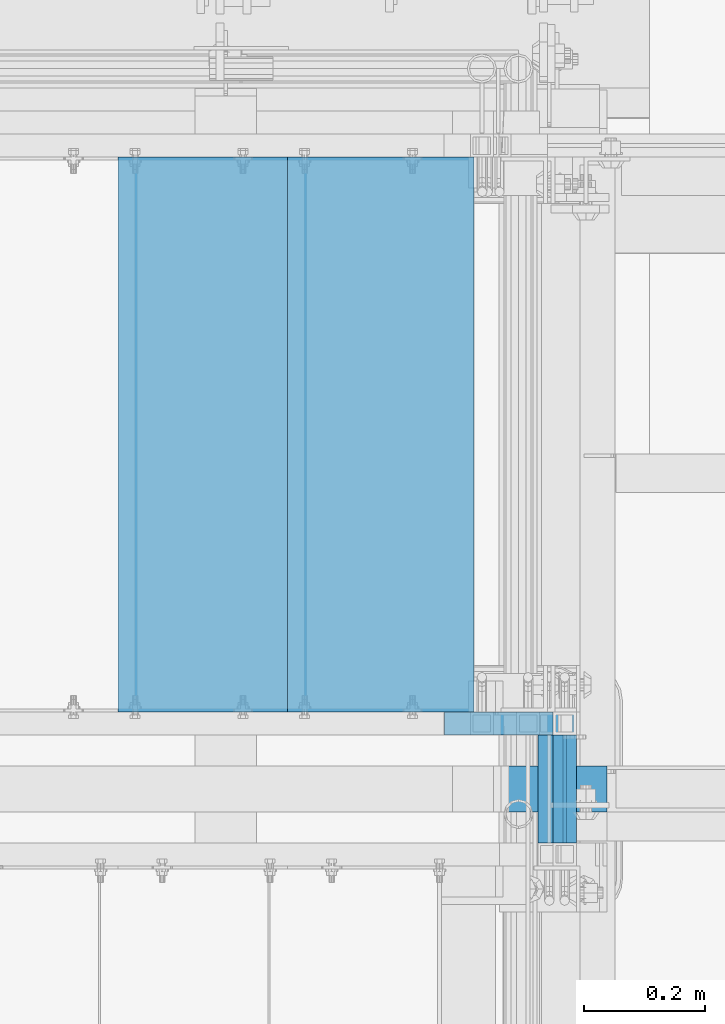
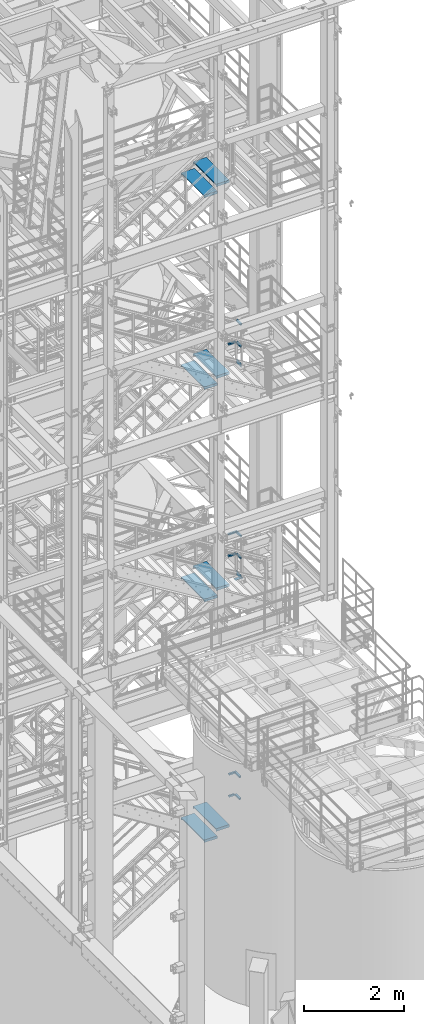
# One storey, part 1198 of 1876: 22 beams, 8 elements without a shape of their own.
"""IFC2X3 building model written with IfcOpenShell, lengths in millimetres."""

from ifc_helpers import new_model, si_unit, frame, origin_with_axes, place, context, subcontext, project, spatial, faceted_brep, material, type_object, element, aggregate, save


model = new_model("IFC2X3")

# Units and contexts
model_context = context("Model", 3, precision=1e-05, world=origin_with_axes())
body_context = subcontext(model_context, "Body", "Model", "MODEL_VIEW")
ifc_project = project(units=[si_unit("LENGTHUNIT", "METRE", prefix="MILLI"), si_unit("AREAUNIT", "SQUARE_METRE"), si_unit("VOLUMEUNIT", "CUBIC_METRE"), si_unit("MASSUNIT", "GRAM", prefix="KILO"), si_unit("TIMEUNIT", "SECOND"), si_unit("PLANEANGLEUNIT", "RADIAN"), si_unit("SOLIDANGLEUNIT", "STERADIAN"), si_unit("THERMODYNAMICTEMPERATUREUNIT", "DEGREE_CELSIUS"), si_unit("LUMINOUSINTENSITYUNIT", "LUMEN")], contexts=[model_context])

# Site, building, storey
site_placement = place(None, origin_with_axes())
site = spatial("IfcSite", under=ifc_project, at=site_placement, CompositionType="ELEMENT")
building_placement = place(site_placement, origin_with_axes())
building = spatial("IfcBuilding", under=site, at=building_placement, Name="Undefined", CompositionType="ELEMENT")
storey_placement = place(building_placement, origin_with_axes())
storey = spatial("IfcBuildingStorey", under=building, at=storey_placement, Name="Undefined", CompositionType="ELEMENT", Elevation=0.0)

# Assembly, beam
assembly_1_placement = place(storey_placement, origin_with_axes())
assembly_1 = element("IfcElementAssembly", 1, at=assembly_1_placement, inside=storey, Name="RAIL", AssemblyPlace="NOTDEFINED", PredefinedType="RIGID_FRAME")
ifc_material_1 = material(Name="STEEL/A36")
beam_type_1 = type_object("IfcBeamType", PredefinedType="NOTDEFINED")
beam_1_placement = place(assembly_1_placement, frame((6273.79999930564, -5753.10000038055, 13382.6249973441), z_axis=(0.0, 0.0, 1.0), x_axis=(0.0, -1.0, 0.0)))
beam_1 = element("IfcBeam", 2, at=beam_1_placement, type_object=beam_type_1, material=ifc_material_1, Name="PLATE", context=body_context, shape_type="Brep", body=[
    faceted_brep([(0.0, 3.17500000000018, -50.8000000000002), (0.0, 3.17500000000018, 50.8000000000002), (177.799998770143, 3.1750000000111, 50.8000000000866), (177.799998770101, 3.1750000000111, -50.7999999999138), (0.0, -3.17500000000018, 50.8000000000002), (177.799998770144, -3.17499999998881, 50.8000000000866), (0.0, -3.17500000000018, -50.8000000000002), (177.799998770101, -3.17499999998881, -50.7999999999138)], [[[0, 1, 2, 3]], [[1, 4, 5, 2]], [[4, 6, 7, 5]], [[6, 0, 3, 7]], [[5, 7, 3, 2]], [[6, 4, 1, 0]]]),
])

assembly_2_placement = place(storey_placement, origin_with_axes())
assembly_2 = element("IfcElementAssembly", 3, at=assembly_2_placement, inside=storey, Name="RAIL", AssemblyPlace="NOTDEFINED", PredefinedType="RIGID_FRAME")
beam_2_placement = place(assembly_2_placement, frame((6273.79999336881, -5753.10000038054, 8226.42499734427), z_axis=(0.0, 0.0, 1.0), x_axis=(0.0, -1.0, 0.0)))
beam_2 = element("IfcBeam", 4, at=beam_2_placement, type_object=beam_type_1, material=ifc_material_1, Name="PLATE", context=body_context, shape_type="Brep", body=[
    faceted_brep([(0.0, 3.17500000000018, -50.8000000000002), (0.0, 3.17500000000018, 50.8000000000002), (177.799998770143, 3.1750000000111, 50.8000000000866), (177.799998770101, 3.1750000000111, -50.7999999999138), (0.0, -3.17500000000018, 50.8000000000002), (177.799998770144, -3.17499999998881, 50.8000000000866), (0.0, -3.17500000000018, -50.8000000000002), (177.799998770101, -3.17499999998881, -50.7999999999138)], [[[0, 1, 2, 3]], [[1, 4, 5, 2]], [[4, 6, 7, 5]], [[6, 0, 3, 7]], [[5, 7, 3, 2]], [[6, 4, 1, 0]]]),
])

# Beam
ifc_material_2 = material()
beam_type_2 = type_object("IfcBeamType", Name="HSS1-1/2X1-1/2X1/8", PredefinedType="NOTDEFINED")
beam_3_placement = place(assembly_1_placement, frame((6273.80000001182, -5753.1000003826, 13843.0000000019), z_axis=(0.0, 0.0, -1.0), x_axis=(0.0, -1.0, 0.0)))
beam_3 = element("IfcBeam", 5, at=beam_3_placement, type_object=beam_type_2, material=ifc_material_2, Name="RAIL", ObjectType="HSS1-1/2X1-1/2X1/8", context=body_context, shape_type="Brep", body=[
    faceted_brep([(-7.27595761418343e-12, 15.8749992829999, -15.8749992829999), (-7.27595761418343e-12, -15.8749992829999, -15.8749992829999), (177.800002232287, -15.8749992829999, -15.8749992829999), (177.800002232287, 15.8749992829999, -15.8749992829999), (5.45696821063757e-12, -15.8749992829999, 15.8749992829999), (177.800002232287, -15.8749992829999, 15.8749992829999), (5.45696821063757e-12, 15.8749992829999, 15.8749992829999), (177.800002232287, 15.8749992829999, 15.8749992829999), (0.0, 19.0499992349996, -19.0499992350001), (0.0, 19.0499992349996, 19.0499992349996), (177.800002232287, 19.0499992349996, 19.0499992349996), (177.800002232287, 19.0499992349996, -19.0499992349996), (0.0, -19.0499992349996, 19.0499992349996), (177.800002232287, -19.0499992349996, 19.0499992349996), (0.0, -19.0499992349996, -19.0499992350001), (177.800002232287, -19.0499992349996, -19.0499992349996)], [[[0, 1, 2, 3]], [[1, 4, 5, 2]], [[4, 6, 7, 5]], [[6, 0, 3, 7]], [[8, 9, 10, 11]], [[9, 12, 13, 10]], [[12, 14, 15, 13]], [[14, 8, 11, 15]], [[13, 15, 11, 10], [5, 7, 3, 2]], [[14, 12, 9, 8], [6, 4, 1, 0]]]),
])

beam_4_placement = place(assembly_1_placement, frame((6273.80000001181, -5753.10000038054, 14376.4000000043), z_axis=(0.0, 0.0, -1.0), x_axis=(0.0, -1.0, 0.0)))
beam_4 = element("IfcBeam", 6, at=beam_4_placement, type_object=beam_type_2, material=ifc_material_2, Name="RAIL", ObjectType="HSS1-1/2X1-1/2X1/8", context=body_context, shape_type="Brep", body=[
    faceted_brep([(-7.27595761418343e-12, 15.8749992829999, -15.8749992829999), (-7.27595761418343e-12, -15.8749992829999, -15.8749992829999), (177.800002232287, -15.8749992829999, -15.8749992829999), (177.800002232287, 15.8749992829999, -15.8749992829999), (5.45696821063757e-12, -15.8749992829999, 15.8749992829999), (177.800002232287, -15.8749992829999, 15.8749992829999), (5.45696821063757e-12, 15.8749992829999, 15.8749992829999), (177.800002232287, 15.8749992829999, 15.8749992829999), (0.0, 19.0499992349996, -19.0499992350001), (0.0, 19.0499992349996, 19.0499992349996), (177.800002232287, 19.0499992349996, 19.0499992349996), (177.800002232287, 19.0499992349996, -19.0499992349996), (0.0, -19.0499992349996, 19.0499992349996), (177.800002232287, -19.0499992349996, 19.0499992349996), (0.0, -19.0499992349996, -19.0499992350001), (177.800002232287, -19.0499992349996, -19.0499992349996)], [[[0, 1, 2, 3]], [[1, 4, 5, 2]], [[4, 6, 7, 5]], [[6, 0, 3, 7]], [[8, 9, 10, 11]], [[9, 12, 13, 10]], [[12, 14, 15, 13]], [[14, 8, 11, 15]], [[13, 15, 11, 10], [5, 7, 3, 2]], [[14, 12, 9, 8], [6, 4, 1, 0]]]),
])

beam_5_placement = place(assembly_2_placement, frame((6273.79999407513, -5753.1000003826, 8686.80000000203), z_axis=(0.0, 0.0, -1.0), x_axis=(0.0, -1.0, 0.0)))
beam_5 = element("IfcBeam", 7, at=beam_5_placement, type_object=beam_type_2, material=ifc_material_2, Name="RAIL", ObjectType="HSS1-1/2X1-1/2X1/8", context=body_context, shape_type="Brep", body=[
    faceted_brep([(-7.27595761418343e-12, 15.8749992829999, -15.8749992829999), (-7.27595761418343e-12, -15.8749992829999, -15.8749992829999), (177.800002232287, -15.8749992829999, -15.8749992829999), (177.800002232287, 15.8749992829999, -15.8749992829999), (5.45696821063757e-12, -15.8749992829999, 15.8749992829999), (177.800002232287, -15.8749992829999, 15.8749992829999), (5.45696821063757e-12, 15.8749992829999, 15.8749992829999), (177.800002232287, 15.8749992829999, 15.8749992829999), (0.0, 19.0499992349996, -19.0499992350001), (0.0, 19.0499992349996, 19.0499992349996), (177.800002232287, 19.0499992349996, 19.0499992349996), (177.800002232287, 19.0499992349996, -19.0499992349996), (0.0, -19.0499992349996, 19.0499992349996), (177.800002232287, -19.0499992349996, 19.0499992349996), (0.0, -19.0499992349996, -19.0499992350001), (177.800002232287, -19.0499992349996, -19.0499992349996)], [[[0, 1, 2, 3]], [[1, 4, 5, 2]], [[4, 6, 7, 5]], [[6, 0, 3, 7]], [[8, 9, 10, 11]], [[9, 12, 13, 10]], [[12, 14, 15, 13]], [[14, 8, 11, 15]], [[13, 15, 11, 10], [5, 7, 3, 2]], [[14, 12, 9, 8], [6, 4, 1, 0]]]),
])

beam_6_placement = place(assembly_2_placement, frame((6273.79999407512, -5753.10000038054, 9220.20000000107), z_axis=(0.0, 0.0, -1.0), x_axis=(0.0, -1.0, 0.0)))
beam_6 = element("IfcBeam", 8, at=beam_6_placement, type_object=beam_type_2, material=ifc_material_2, Name="RAIL", ObjectType="HSS1-1/2X1-1/2X1/8", context=body_context, shape_type="Brep", body=[
    faceted_brep([(-7.27595761418343e-12, 15.8749992829999, -15.8749992829999), (-7.27595761418343e-12, -15.8749992829999, -15.8749992829999), (177.800002232287, -15.8749992829999, -15.8749992829999), (177.800002232287, 15.8749992829999, -15.8749992829999), (5.45696821063757e-12, -15.8749992829999, 15.8749992829999), (177.800002232287, -15.8749992829999, 15.8749992829999), (5.45696821063757e-12, 15.8749992829999, 15.8749992829999), (177.800002232287, 15.8749992829999, 15.8749992829999), (0.0, 19.0499992349996, -19.0499992350001), (0.0, 19.0499992349996, 19.0499992349996), (177.800002232287, 19.0499992349996, 19.0499992349996), (177.800002232287, 19.0499992349996, -19.0499992349996), (0.0, -19.0499992349996, 19.0499992349996), (177.800002232287, -19.0499992349996, 19.0499992349996), (0.0, -19.0499992349996, -19.0499992350001), (177.800002232287, -19.0499992349996, -19.0499992349996)], [[[0, 1, 2, 3]], [[1, 4, 5, 2]], [[4, 6, 7, 5]], [[6, 0, 3, 7]], [[8, 9, 10, 11]], [[9, 12, 13, 10]], [[12, 14, 15, 13]], [[14, 8, 11, 15]], [[13, 15, 11, 10], [5, 7, 3, 2]], [[14, 12, 9, 8], [6, 4, 1, 0]]]),
])

# Assembly, beams
assembly_3_placement = place(storey_placement, origin_with_axes())
assembly_3 = element("IfcElementAssembly", 9, at=assembly_3_placement, inside=storey, Name="RAIL", AssemblyPlace="NOTDEFINED", PredefinedType="RIGID_FRAME")
beam_7_placement = place(assembly_3_placement, frame((6248.400000012, -5753.1000003826, 2837.68341294587), z_axis=(0.0, 0.0, -1.0), x_axis=(0.0, -1.0, 0.0)))
beam_7 = element("IfcBeam", 10, at=beam_7_placement, type_object=beam_type_2, material=ifc_material_2, Name="RAIL", ObjectType="HSS1-1/2X1-1/2X1/8", context=body_context, shape_type="Brep", body=[
    faceted_brep([(-7.27595761418343e-12, 15.8749992829999, -15.8749992829999), (-7.27595761418343e-12, -15.8749992829999, -15.8749992829999), (177.800002232287, -15.8749992829999, -15.8749992829999), (177.800002232287, 15.8749992829999, -15.8749992829999), (5.45696821063757e-12, -15.8749992829999, 15.8749992829999), (177.800002232287, -15.8749992829999, 15.8749992829999), (5.45696821063757e-12, 15.8749992829999, 15.8749992829999), (177.800002232287, 15.8749992829999, 15.8749992829999), (0.0, 19.0499992349996, -19.0499992350001), (0.0, 19.0499992349996, 19.0499992349996), (177.800002232287, 19.0499992349996, 19.0499992349996), (177.800002232287, 19.0499992349996, -19.0499992349996), (0.0, -19.0499992349996, 19.0499992349996), (177.800002232287, -19.0499992349996, 19.0499992349996), (0.0, -19.0499992349996, -19.0499992350001), (177.800002232287, -19.0499992349996, -19.0499992349996)], [[[0, 1, 2, 3]], [[1, 4, 5, 2]], [[4, 6, 7, 5]], [[6, 0, 3, 7]], [[8, 9, 10, 11]], [[9, 12, 13, 10]], [[12, 14, 15, 13]], [[14, 8, 11, 15]], [[13, 15, 11, 10], [5, 7, 3, 2]], [[14, 12, 9, 8], [6, 4, 1, 0]]]),
])
beam_8_placement = place(assembly_3_placement, frame((6248.40000001199, -5753.10000038054, 3371.08362061188), z_axis=(0.0, 0.0, -1.0), x_axis=(0.0, -1.0, 0.0)))
beam_8 = element("IfcBeam", 11, at=beam_8_placement, type_object=beam_type_2, material=ifc_material_2, Name="RAIL", ObjectType="HSS1-1/2X1-1/2X1/8", context=body_context, shape_type="Brep", body=[
    faceted_brep([(-7.27595761418343e-12, 15.8749992829999, -15.8749992829999), (-7.27595761418343e-12, -15.8749992829999, -15.8749992829999), (177.800002232287, -15.8749992829999, -15.8749992829999), (177.800002232287, 15.8749992829999, -15.8749992829999), (5.45696821063757e-12, -15.8749992829999, 15.8749992829999), (177.800002232287, -15.8749992829999, 15.8749992829999), (5.45696821063757e-12, 15.8749992829999, 15.8749992829999), (177.800002232287, 15.8749992829999, 15.8749992829999), (0.0, 19.0499992349996, -19.0499992350001), (0.0, 19.0499992349996, 19.0499992349996), (177.800002232287, 19.0499992349996, 19.0499992349996), (177.800002232287, 19.0499992349996, -19.0499992349996), (0.0, -19.0499992349996, 19.0499992349996), (177.800002232287, -19.0499992349996, 19.0499992349996), (0.0, -19.0499992349996, -19.0499992350001), (177.800002232287, -19.0499992349996, -19.0499992349996)], [[[0, 1, 2, 3]], [[1, 4, 5, 2]], [[4, 6, 7, 5]], [[6, 0, 3, 7]], [[8, 9, 10, 11]], [[9, 12, 13, 10]], [[12, 14, 15, 13]], [[14, 8, 11, 15]], [[13, 15, 11, 10], [5, 7, 3, 2]], [[14, 12, 9, 8], [6, 4, 1, 0]]]),
])
beam_9_placement = place(assembly_3_placement, frame((6096.00000038111, -5734.05000114554, 2837.68362061127), z_axis=(0.0, 0.0, 1.0), x_axis=(1.0, 0.0, 0.0)))
beam_9 = element("IfcBeam", 12, at=beam_9_placement, type_object=beam_type_2, material=ifc_material_2, Name="RAIL", ObjectType="HSS1-1/2X1-1/2X1/8", context=body_context, shape_type="Brep", body=[
    faceted_brep([(4.61079483309095, 15.8749992829999, -15.8749992829999), (4.61079483309095, -15.8749992829999, -15.8749992829999), (133.350000395892, -15.8749992829999, -15.8749992829999), (133.350000395892, 15.8749992829999, -15.8749992829999), (-4.61079482670993, -15.8749992829999, 15.8749992829999), (133.350000395892, -15.8749992829999, 15.8749992829999), (-4.61079482670993, 15.8749992829999, 15.8749992829999), (133.350000395892, 15.8749992829999, 15.8749992829999), (5.5329538267797, 19.0499992349996, -19.0499992350001), (-5.53295382039778, 19.0499992349996, 19.0499992350001), (133.350000395892, 19.0499992349996, 19.0499992350001), (133.350000395892, 19.0499992349996, -19.0499992350001), (-5.53295382039778, -19.0499992349996, 19.0499992350001), (133.350000395892, -19.0499992349996, 19.0499992350001), (5.5329538267797, -19.0499992349996, -19.0499992350001), (133.350000395892, -19.0499992349996, -19.0499992350001)], [[[0, 1, 2, 3]], [[1, 4, 5, 2]], [[4, 6, 7, 5]], [[6, 0, 3, 7]], [[8, 9, 10, 11]], [[9, 12, 13, 10]], [[12, 14, 15, 13]], [[14, 8, 11, 15]], [[13, 15, 11, 10], [5, 7, 3, 2]], [[14, 12, 9, 8], [6, 4, 1, 0]]]),
])
beam_10_placement = place(assembly_3_placement, frame((6248.400000012, -5734.05000114554, 3371.08362061127), z_axis=(0.0, 0.0, -1.0), x_axis=(-1.0, 0.0, 0.0)))
beam_10 = element("IfcBeam", 13, at=beam_10_placement, type_object=beam_type_2, material=ifc_material_2, Name="RAIL", ObjectType="HSS1-1/2X1-1/2X1/8", context=body_context, shape_type="Brep", body=[
    faceted_brep([(-15.875, 15.8749981318675, -15.875), (-15.875, -15.8750000000011, -15.875), (157.010794458642, -15.8749992829999, -15.8749992829999), (157.010794458642, 15.8749992829999, -15.8749992829999), (15.875, -15.8750000000011, 15.875), (147.789204798841, -15.8749992829999, 15.8749992829999), (15.875, 15.8749981318675, 15.875), (147.789204798841, 15.8749992829999, 15.8749992829999), (-19.049999234363, 19.0499992349996, -19.0499992350001), (19.0500000000002, 19.0499992349996, 19.0499992350001), (146.867045805153, 19.0499992349996, 19.0499992350001), (157.93295345233, 19.0499992349996, -19.0499992350001), (19.0500000000002, -19.0499992349996, 19.0499992350001), (146.867045805153, -19.0499992349996, 19.0499992350001), (-19.049999234363, -19.0499992349996, -19.0499992350001), (157.93295345233, -19.0499992349996, -19.0499992350001)], [[[0, 1, 2, 3]], [[1, 4, 5, 2]], [[4, 6, 7, 5]], [[6, 0, 3, 7]], [[8, 9, 10, 11]], [[9, 12, 13, 10]], [[12, 14, 15, 13]], [[14, 8, 11, 15]], [[13, 15, 11, 10], [5, 7, 3, 2]], [[14, 12, 9, 8], [6, 4, 1, 0]]]),
])
aggregate(assembly_3, [beam_7, beam_8, beam_9, beam_10])

# Beam
beam_11_placement = place(assembly_2_placement, frame((6081.03214535802, -5734.05000114554, 8686.8), z_axis=(0.0, 0.0, 1.0), x_axis=(1.0, 0.0, 0.0)))
beam_11 = element("IfcBeam", 14, at=beam_11_placement, type_object=beam_type_2, material=ifc_material_2, Name="RAIL", ObjectType="HSS1-1/2X1-1/2X1/8", context=body_context, shape_type="Brep", body=[
    faceted_brep([(4.62281070603149, 15.8749992829999, -15.8749992829999), (4.62281070603149, -15.8749992829999, -15.8749992829999), (173.717849483728, -15.8749992829999, -15.8749992829999), (173.717849483728, 15.8749992829999, -15.8749992829999), (-4.62281069892288, -15.8749992829999, 15.8749992829999), (173.717849483728, -15.8749992829999, 15.8749992829999), (-4.62281069892288, 15.8749992829999, 15.8749992829999), (173.717849483728, 15.8749992829999, 15.8749992829999), (5.54737287430726, 19.0499992349996, -19.0499992349996), (-5.54737286719865, 19.0499992349996, 19.0499992349996), (173.717849483728, 19.0499992349996, 19.0499992349996), (173.717849483728, 19.0499992349996, -19.0499992349996), (-5.54737286719865, -19.0499992349996, 19.0499992349996), (173.717849483728, -19.0499992349996, 19.0499992349996), (5.54737287430726, -19.0499992349996, -19.0499992349996), (173.717849483728, -19.0499992349996, -19.0499992349996)], [[[0, 1, 2, 3]], [[1, 4, 5, 2]], [[4, 6, 7, 5]], [[6, 0, 3, 7]], [[8, 9, 10, 11]], [[9, 12, 13, 10]], [[12, 14, 15, 13]], [[14, 8, 11, 15]], [[13, 15, 11, 10], [5, 7, 3, 2]], [[14, 12, 9, 8], [6, 4, 1, 0]]]),
])

beam_12_placement = place(assembly_2_placement, frame((6273.79999407756, -5734.05000114554, 9220.2), z_axis=(0.0, 0.0, -1.0), x_axis=(-1.0, 0.0, 0.0)))
beam_12 = element("IfcBeam", 15, at=beam_12_placement, type_object=beam_type_2, material=ifc_material_2, Name="RAIL", ObjectType="HSS1-1/2X1-1/2X1/8", context=body_context, shape_type="Brep", body=[
    faceted_brep([(-15.875, 15.8749981318675, -15.875), (-15.875, -15.8750000000011, -15.875), (197.39065942693, -15.8749992829999, -15.8749992829999), (197.39065942693, 15.8749992829999, -15.8749992829999), (15.875, -15.8750000000011, 15.875), (188.145038021976, -15.8749992829999, 15.8749992829999), (15.875, 15.8749981318675, 15.875), (188.145038021976, 15.8749992829999, 15.8749992829999), (-19.049999234363, 19.0499992349996, -19.0499992350001), (19.0500000000002, 19.0499992349996, 19.0499992350001), (187.2204758537, 19.0499992349996, 19.0499992349996), (198.315221595206, 19.0499992349996, -19.0499992349996), (19.0500000000002, -19.0499992349996, 19.0499992350001), (187.2204758537, -19.0499992349996, 19.0499992349996), (-19.049999234363, -19.0499992349996, -19.0499992350001), (198.315221595206, -19.0499992349996, -19.0499992349996)], [[[0, 1, 2, 3]], [[1, 4, 5, 2]], [[4, 6, 7, 5]], [[6, 0, 3, 7]], [[8, 9, 10, 11]], [[9, 12, 13, 10]], [[12, 14, 15, 13]], [[14, 8, 11, 15]], [[13, 15, 11, 10], [5, 7, 3, 2]], [[14, 12, 9, 8], [6, 4, 1, 0]]]),
])

aggregate(assembly_2, [beam_2, beam_5, beam_6, beam_11, beam_12])

beam_13_placement = place(assembly_1_placement, frame((6080.51600984068, -5734.05000114554, 13843.0000000019), z_axis=(0.0, 0.0, 1.0), x_axis=(1.0, 0.0, 0.0)))
beam_13 = element("IfcBeam", 16, at=beam_13_placement, type_object=beam_type_2, material=ifc_material_2, Name="RAIL", ObjectType="HSS1-1/2X1-1/2X1/8", context=body_context, shape_type="Brep", body=[
    faceted_brep([(4.49184492398945, 15.8749992829999, -15.8749992829999), (4.49184492398945, -15.8749992829999, -15.8749992829999), (174.233990936133, -15.8749992829999, -15.8749992829999), (174.233990936133, 15.8749992829999, -15.8749992829999), (-4.49184492818313, -15.8749992829999, 15.8749992829999), (174.233990936133, -15.8749992829999, 15.8749992829999), (-4.49184492818313, 15.8749992829999, 15.8749992829999), (174.233990936133, 15.8749992829999, 15.8749992829999), (5.39021393619987, 19.0499992349996, -19.0499992349996), (-5.39021394039355, 19.0499992349996, 19.0499992349996), (174.233990936133, 19.0499992349996, 19.0499992349996), (174.233990936133, 19.0499992349996, -19.0499992349996), (-5.39021394039355, -19.0499992349996, 19.0499992349996), (174.233990936133, -19.0499992349996, 19.0499992349996), (5.39021393619987, -19.0499992349996, -19.0499992349996), (174.233990936133, -19.0499992349996, -19.0499992349996)], [[[0, 1, 2, 3]], [[1, 4, 5, 2]], [[4, 6, 7, 5]], [[6, 0, 3, 7]], [[8, 9, 10, 11]], [[9, 12, 13, 10]], [[12, 14, 15, 13]], [[14, 8, 11, 15]], [[13, 15, 11, 10], [5, 7, 3, 2]], [[14, 12, 9, 8], [6, 4, 1, 0]]]),
])

aggregate(assembly_1, [beam_1, beam_3, beam_4, beam_13])

# Assembly, beams
assembly_4_placement = place(storey_placement, origin_with_axes())
assembly_4 = element("IfcElementAssembly", 17, at=assembly_4_placement, inside=storey, Name="STRINGER", AssemblyPlace="NOTDEFINED", PredefinedType="RIGID_FRAME")
beam_type_3 = type_object("IfcBeamType", PredefinedType="NOTDEFINED")
beam_14_placement = place(assembly_4_placement, frame((5970.58749716898, -5710.23700114168, 17810.103704755), z_axis=(-1.0, 0.0, 0.0), x_axis=(0.0, 1.0, 0.0)))
beam_14 = element("IfcBeam", 18, at=beam_14_placement, type_object=beam_type_3, material=ifc_material_1, Name="TREAD", context=body_context, shape_type="Brep", body=[
    faceted_brep([(-7.45785655453801e-11, 53.9750000000167, -153.9875), (-7.45785655453801e-11, 53.9750000000167, 153.987506103515), (0.0, 9.52499999999964, 153.9875), (-7.45785655453801e-11, 9.52499999999964, -153.9875), (-4.76300000007541, 53.9750000000167, -153.9875), (-4.76300000007541, 53.9750000000167, 153.987506103515), (-4.76300000007541, -9.52499999998327, -153.9875), (-4.76300000007541, -9.52500000019427, 153.987536621094), (909.637000008669, -9.52500000248983, 153.987506103515), (909.637000008669, 53.9749999975102, 153.987506103515), (904.87400000867, 53.9749999975102, 153.987506103515), (904.87400000867, 9.52499999999964, 153.987506103515), (-7.45785655453801e-11, -9.52500000019427, 153.987536621094), (904.87400000867, -9.52500000248983, 153.987506103515), (904.87400000867, 9.52499999999964, -153.9875), (909.637000008669, -9.52500000248983, -153.9875), (909.637000008669, 53.9749999975102, -153.9875), (904.87400000867, 53.9749999975102, -153.9875)], [[[0, 1, 2, 3]], [[1, 0, 4, 5]], [[5, 4, 6, 7]], [[8, 9, 10, 11, 2, 1, 5, 7, 12, 13]], [[14, 3, 2, 11]], [[15, 8, 13, 12, 7, 6]], [[9, 16, 17, 10]], [[16, 9, 8, 15]], [[16, 15, 6, 4, 0, 3, 14, 17]], [[10, 17, 14, 11]]]),
])
beam_15_placement = place(assembly_4_placement, frame((5691.18749692326, -5710.23700114221, 17637.0074083469), z_axis=(-1.0, 0.0, 0.0), x_axis=(0.0, 1.0, 0.0)))
beam_15 = element("IfcBeam", 19, at=beam_15_placement, type_object=beam_type_3, material=ifc_material_1, Name="TREAD", context=body_context, shape_type="Brep", body=[
    faceted_brep([(-7.45785655453801e-11, 53.9750000000167, -153.9875), (-7.45785655453801e-11, 53.9750000000167, 153.987506103515), (0.0, 9.52499999999964, 153.9875), (-7.45785655453801e-11, 9.52499999999964, -153.9875), (-4.76300000007541, 53.9750000000167, -153.9875), (-4.76300000007541, 53.9750000000167, 153.987506103515), (-4.76300000007541, -9.52499999998327, -153.9875), (-4.76300000007541, -9.52500000019427, 153.987536621094), (909.637000008669, -9.52500000248983, 153.987506103515), (909.637000008669, 53.9749999975102, 153.987506103515), (904.87400000867, 53.9749999975102, 153.987506103515), (904.87400000867, 9.52499999999964, 153.987506103515), (-7.45785655453801e-11, -9.52500000019427, 153.987536621094), (904.87400000867, -9.52500000248983, 153.987506103515), (904.87400000867, 9.52499999999964, -153.9875), (909.637000008669, -9.52500000248983, -153.9875), (909.637000008669, 53.9749999975102, -153.9875), (904.87400000867, 53.9749999975102, -153.9875)], [[[0, 1, 2, 3]], [[1, 0, 4, 5]], [[5, 4, 6, 7]], [[8, 9, 10, 11, 2, 1, 5, 7, 12, 13]], [[14, 3, 2, 11]], [[15, 8, 13, 12, 7, 6]], [[9, 16, 17, 10]], [[16, 9, 8, 15]], [[16, 15, 6, 4, 0, 3, 14, 17]], [[10, 17, 14, 11]]]),
])
aggregate(assembly_4, [beam_14, beam_15])

assembly_5_placement = place(storey_placement, origin_with_axes())
assembly_5 = element("IfcElementAssembly", 20, at=assembly_5_placement, inside=storey, Name="STRINGER", AssemblyPlace="NOTDEFINED", PredefinedType="RIGID_FRAME")
beam_16_placement = place(assembly_5_placement, frame((5970.58750008514, -5710.23700114556, 13137.7266666865), z_axis=(-1.0, 0.0, 0.0), x_axis=(0.0, 1.0, 0.0)))
beam_16 = element("IfcBeam", 21, at=beam_16_placement, type_object=beam_type_3, material=ifc_material_1, Name="TREAD", context=body_context, shape_type="Brep", body=[
    faceted_brep([(-7.45785655453801e-11, 53.9750000000167, -153.9875), (-7.45785655453801e-11, 53.9750000000167, 153.987506103515), (0.0, 9.52499999999964, 153.9875), (-7.45785655453801e-11, 9.52499999999964, -153.9875), (-4.76300000007541, 53.9750000000167, -153.9875), (-4.76300000007541, 53.9750000000167, 153.987506103515), (-4.76300000007541, -9.52499999998327, -153.9875), (-4.76300000007541, -9.52500000019427, 153.987536621094), (909.637000008669, -9.52500000248983, 153.987506103515), (909.637000008669, 53.9749999975102, 153.987506103515), (904.87400000867, 53.9749999975102, 153.987506103515), (904.87400000867, 9.52499999999964, 153.987506103515), (-7.45785655453801e-11, -9.52500000019427, 153.987536621094), (904.87400000867, -9.52500000248983, 153.987506103515), (904.87400000867, 9.52499999999964, -153.9875), (909.637000008669, -9.52500000248983, -153.9875), (909.637000008669, 53.9749999975102, -153.9875), (904.87400000867, 53.9749999975102, -153.9875)], [[[0, 1, 2, 3]], [[1, 0, 4, 5]], [[5, 4, 6, 7]], [[8, 9, 10, 11, 2, 1, 5, 7, 12, 13]], [[14, 3, 2, 11]], [[15, 8, 13, 12, 7, 6]], [[9, 16, 17, 10]], [[16, 9, 8, 15]], [[16, 15, 6, 4, 0, 3, 14, 17]], [[10, 17, 14, 11]]]),
])
beam_17_placement = place(assembly_5_placement, frame((5691.18750017887, -5710.23700114556, 12965.8533333532), z_axis=(-1.0, 0.0, 0.0), x_axis=(0.0, 1.0, 0.0)))
beam_17 = element("IfcBeam", 22, at=beam_17_placement, type_object=beam_type_3, material=ifc_material_1, Name="TREAD", context=body_context, shape_type="Brep", body=[
    faceted_brep([(-7.45785655453801e-11, 53.9750000000167, -153.9875), (-7.45785655453801e-11, 53.9750000000167, 153.987506103515), (0.0, 9.52499999999964, 153.9875), (-7.45785655453801e-11, 9.52499999999964, -153.9875), (-4.76300000007541, 53.9750000000167, -153.9875), (-4.76300000007541, 53.9750000000167, 153.987506103515), (-4.76300000007541, -9.52499999998327, -153.9875), (-4.76300000007541, -9.52500000019427, 153.987536621094), (909.637000008669, -9.52500000248983, 153.987506103515), (909.637000008669, 53.9749999975102, 153.987506103515), (904.87400000867, 53.9749999975102, 153.987506103515), (904.87400000867, 9.52499999999964, 153.987506103515), (-7.45785655453801e-11, -9.52500000019427, 153.987536621094), (904.87400000867, -9.52500000248983, 153.987506103515), (904.87400000867, 9.52499999999964, -153.9875), (909.637000008669, -9.52500000248983, -153.9875), (909.637000008669, 53.9749999975102, -153.9875), (904.87400000867, 53.9749999975102, -153.9875)], [[[0, 1, 2, 3]], [[1, 0, 4, 5]], [[5, 4, 6, 7]], [[8, 9, 10, 11, 2, 1, 5, 7, 12, 13]], [[14, 3, 2, 11]], [[15, 8, 13, 12, 7, 6]], [[9, 16, 17, 10]], [[16, 9, 8, 15]], [[16, 15, 6, 4, 0, 3, 14, 17]], [[10, 17, 14, 11]]]),
])
aggregate(assembly_5, [beam_16, beam_17])

assembly_6_placement = place(storey_placement, origin_with_axes())
assembly_6 = element("IfcElementAssembly", 23, at=assembly_6_placement, inside=storey, Name="STRINGER", AssemblyPlace="NOTDEFINED", PredefinedType="RIGID_FRAME")
beam_18_placement = place(assembly_6_placement, frame((5970.58749446524, -5710.23700113625, 7975.5999987069), z_axis=(-1.0, 0.0, 0.0), x_axis=(0.0, 1.0, 0.0)))
beam_18 = element("IfcBeam", 24, at=beam_18_placement, type_object=beam_type_3, material=ifc_material_1, Name="TREAD", context=body_context, shape_type="Brep", body=[
    faceted_brep([(-7.45785655453801e-11, 53.9750000000167, -153.9875), (-7.45785655453801e-11, 53.9750000000167, 153.987506103515), (0.0, 9.52499999999964, 153.9875), (-7.45785655453801e-11, 9.52499999999964, -153.9875), (-4.76300000007541, 53.9750000000167, -153.9875), (-4.76300000007541, 53.9750000000167, 153.987506103515), (-4.76300000007541, -9.52499999998327, -153.9875), (-4.76300000007541, -9.52500000019427, 153.987536621094), (909.637000008669, -9.52500000248983, 153.987506103515), (909.637000008669, 53.9749999975102, 153.987506103515), (904.87400000867, 53.9749999975102, 153.987506103515), (904.87400000867, 9.52499999999964, 153.987506103515), (-7.45785655453801e-11, -9.52500000019427, 153.987536621094), (904.87400000867, -9.52500000248983, 153.987506103515), (904.87400000867, 9.52499999999964, -153.9875), (909.637000008669, -9.52500000248983, -153.9875), (909.637000008669, 53.9749999975102, -153.9875), (904.87400000867, 53.9749999975102, -153.9875)], [[[0, 1, 2, 3]], [[1, 0, 4, 5]], [[5, 4, 6, 7]], [[8, 9, 10, 11, 2, 1, 5, 7, 12, 13]], [[14, 3, 2, 11]], [[15, 8, 13, 12, 7, 6]], [[9, 16, 17, 10]], [[16, 9, 8, 15]], [[16, 15, 6, 4, 0, 3, 14, 17]], [[10, 17, 14, 11]]]),
])
beam_19_placement = place(assembly_6_placement, frame((5691.18749485534, -5710.23700113625, 7797.79999878767), z_axis=(-1.0, 0.0, 0.0), x_axis=(0.0, 1.0, 0.0)))
beam_19 = element("IfcBeam", 25, at=beam_19_placement, type_object=beam_type_3, material=ifc_material_1, Name="TREAD", context=body_context, shape_type="Brep", body=[
    faceted_brep([(-7.45785655453801e-11, 53.9750000000167, -153.9875), (-7.45785655453801e-11, 53.9750000000167, 153.987506103515), (0.0, 9.52499999999964, 153.9875), (-7.45785655453801e-11, 9.52499999999964, -153.9875), (-4.76300000007541, 53.9750000000167, -153.9875), (-4.76300000007541, 53.9750000000167, 153.987506103515), (-4.76300000007541, -9.52499999998327, -153.9875), (-4.76300000007541, -9.52500000019427, 153.987536621094), (909.637000008669, -9.52500000248983, 153.987506103515), (909.637000008669, 53.9749999975102, 153.987506103515), (904.87400000867, 53.9749999975102, 153.987506103515), (904.87400000867, 9.52499999999964, 153.987506103515), (-7.45785655453801e-11, -9.52500000019427, 153.987536621094), (904.87400000867, -9.52500000248983, 153.987506103515), (904.87400000867, 9.52499999999964, -153.9875), (909.637000008669, -9.52500000248983, -153.9875), (909.637000008669, 53.9749999975102, -153.9875), (904.87400000867, 53.9749999975102, -153.9875)], [[[0, 1, 2, 3]], [[1, 0, 4, 5]], [[5, 4, 6, 7]], [[8, 9, 10, 11, 2, 1, 5, 7, 12, 13]], [[14, 3, 2, 11]], [[15, 8, 13, 12, 7, 6]], [[9, 16, 17, 10]], [[16, 9, 8, 15]], [[16, 15, 6, 4, 0, 3, 14, 17]], [[10, 17, 14, 11]]]),
])
aggregate(assembly_6, [beam_18, beam_19])

assembly_7_placement = place(storey_placement, origin_with_axes())
assembly_7 = element("IfcElementAssembly", 26, at=assembly_7_placement, inside=storey, Name="STRINGER", AssemblyPlace="NOTDEFINED", PredefinedType="RIGID_FRAME")
beam_20_placement = place(assembly_7_placement, frame((5970.58750066187, -5710.23700121136, 2117.50603396813), z_axis=(-1.0, 0.0, 0.0), x_axis=(0.0, 1.0, 0.0)))
beam_20 = element("IfcBeam", 27, at=beam_20_placement, type_object=beam_type_3, material=ifc_material_1, Name="TREAD", context=body_context, shape_type="Brep", body=[
    faceted_brep([(-7.45785655453801e-11, 53.9750000000167, -153.9875), (-7.45785655453801e-11, 53.9750000000167, 153.987506103515), (0.0, 9.52499999999964, 153.9875), (-7.45785655453801e-11, 9.52499999999964, -153.9875), (-4.76300000007541, 53.9750000000167, -153.9875), (-4.76300000007541, 53.9750000000167, 153.987506103515), (-4.76300000007541, -9.52499999998327, -153.9875), (-4.76300000007541, -9.52500000019427, 153.987536621094), (909.637000008669, -9.52500000248983, 153.987506103515), (909.637000008669, 53.9749999975102, 153.987506103515), (904.87400000867, 53.9749999975102, 153.987506103515), (904.87400000867, 9.52499999999964, 153.987506103515), (-7.45785655453801e-11, -9.52500000019427, 153.987536621094), (904.87400000867, -9.52500000248983, 153.987506103515), (904.87400000867, 9.52499999999964, -153.9875), (909.637000008669, -9.52500000248983, -153.9875), (909.637000008669, 53.9749999975102, -153.9875), (904.87400000867, 53.9749999975102, -153.9875)], [[[0, 1, 2, 3]], [[1, 0, 4, 5]], [[5, 4, 6, 7]], [[8, 9, 10, 11, 2, 1, 5, 7, 12, 13]], [[14, 3, 2, 11]], [[15, 8, 13, 12, 7, 6]], [[9, 16, 17, 10]], [[16, 9, 8, 15]], [[16, 15, 6, 4, 0, 3, 14, 17]], [[10, 17, 14, 11]]]),
])
beam_21_placement = place(assembly_7_placement, frame((5691.1875006347, -5710.23700121136, 1940.25344780406), z_axis=(-1.0, 0.0, 0.0), x_axis=(0.0, 1.0, 0.0)))
beam_21 = element("IfcBeam", 28, at=beam_21_placement, type_object=beam_type_3, material=ifc_material_1, Name="TREAD", context=body_context, shape_type="Brep", body=[
    faceted_brep([(-7.45785655453801e-11, 53.9750000000167, -153.9875), (-7.45785655453801e-11, 53.9750000000167, 153.987506103515), (0.0, 9.52499999999964, 153.9875), (-7.45785655453801e-11, 9.52499999999964, -153.9875), (-4.76300000007541, 53.9750000000167, -153.9875), (-4.76300000007541, 53.9750000000167, 153.987506103515), (-4.76300000007541, -9.52499999998327, -153.9875), (-4.76300000007541, -9.52500000019427, 153.987536621094), (909.637000008669, -9.52500000248983, 153.987506103515), (909.637000008669, 53.9749999975102, 153.987506103515), (904.87400000867, 53.9749999975102, 153.987506103515), (904.87400000867, 9.52499999999964, 153.987506103515), (-7.45785655453801e-11, -9.52500000019427, 153.987536621094), (904.87400000867, -9.52500000248983, 153.987506103515), (904.87400000867, 9.52499999999964, -153.9875), (909.637000008669, -9.52500000248983, -153.9875), (909.637000008669, 53.9749999975102, -153.9875), (904.87400000867, 53.9749999975102, -153.9875)], [[[0, 1, 2, 3]], [[1, 0, 4, 5]], [[5, 4, 6, 7]], [[8, 9, 10, 11, 2, 1, 5, 7, 12, 13]], [[14, 3, 2, 11]], [[15, 8, 13, 12, 7, 6]], [[9, 16, 17, 10]], [[16, 9, 8, 15]], [[16, 15, 6, 4, 0, 3, 14, 17]], [[10, 17, 14, 11]]]),
])
aggregate(assembly_7, [beam_20, beam_21])

# Assembly, beam
assembly_8_placement = place(storey_placement, origin_with_axes())
assembly_8 = element("IfcElementAssembly", 29, at=assembly_8_placement, inside=storey, Name="ref.", AssemblyPlace="NOTDEFINED", PredefinedType="RIGID_FRAME")
ifc_material_3 = material(Name="STEEL/Steel_Undefined")
beam_type_4 = type_object("IfcBeamType", PredefinedType="NOTDEFINED")
beam_22_placement = place(assembly_8_placement, frame((6169.02500000335, -5842.00000113861, 8150.225), z_axis=(0.0, -1.0, 0.0), x_axis=(1.0, 0.0, 0.0)))
beam_22 = element("IfcBeam", 30, at=beam_22_placement, type_object=beam_type_4, material=ifc_material_3, Name="ref.", context=body_context, shape_type="Brep", body=[
    faceted_brep([(0.0, 3.17500000000018, -38.1000000000004), (0.0, 3.17500000000018, 38.1000000000004), (174.624999999249, 3.17500000000018, 38.1000000000004), (174.624999999249, 3.17500000000018, -38.1000000000004), (0.0, -3.17500000000018, 38.1000000000004), (174.624999999249, -3.17500000000018, 38.1000000000004), (0.0, -3.17500000000018, -38.1000000000004), (174.624999999249, -3.17500000000018, -38.1000000000004)], [[[0, 1, 2, 3]], [[1, 4, 5, 2]], [[4, 6, 7, 5]], [[6, 0, 3, 7]], [[5, 7, 3, 2]], [[6, 4, 1, 0]]]),
])
aggregate(assembly_8, [beam_22])

save(model, "model.ifc")
